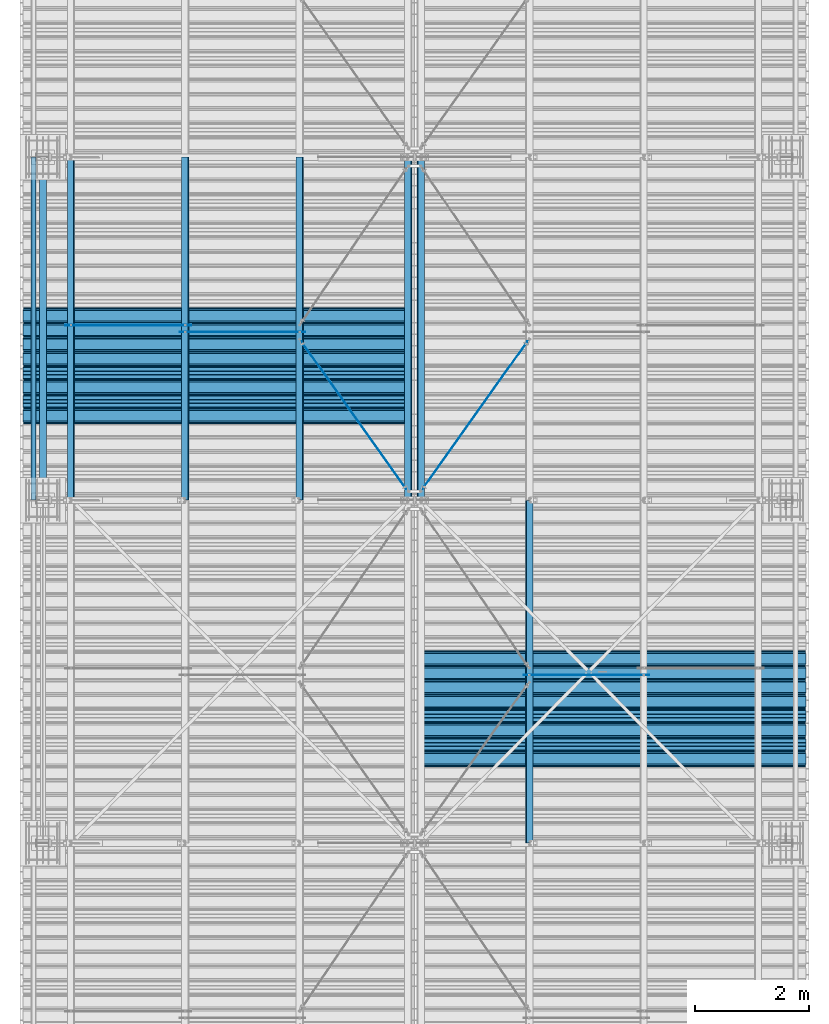
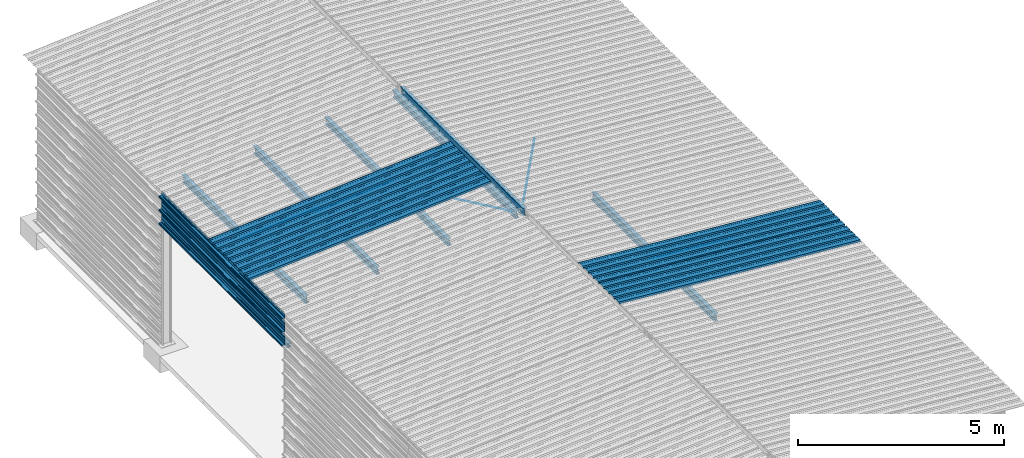
# One storey, part 12 of 70: 19 beams, 19 elements without a shape of their own.
"""IFC2X3 building model written with IfcOpenShell, lengths in millimetres."""

from ifc_helpers import new_model, si_unit, frame, origin_with_axes, origin_2d_with_axis, place, context, subcontext, project, spatial, polyline, circle, i_section, outline, extrude, clip, halfspace, material, type_object, element, aggregate, save


model = new_model("IFC2X3")

# Units and contexts
model_context = context("Model", 3, precision=1e-05, world=origin_with_axes())
body_context = subcontext(model_context, "Body", "Model", "MODEL_VIEW")
ifc_project = project(units=[si_unit("LENGTHUNIT", "METRE", prefix="MILLI"), si_unit("AREAUNIT", "SQUARE_METRE"), si_unit("VOLUMEUNIT", "CUBIC_METRE"), si_unit("MASSUNIT", "GRAM", prefix="KILO"), si_unit("TIMEUNIT", "SECOND"), si_unit("PLANEANGLEUNIT", "RADIAN"), si_unit("SOLIDANGLEUNIT", "STERADIAN"), si_unit("THERMODYNAMICTEMPERATUREUNIT", "DEGREE_CELSIUS"), si_unit("LUMINOUSINTENSITYUNIT", "LUMEN")], contexts=[model_context])

# Site, building, storey
site_placement = place(None, origin_with_axes())
site = spatial("IfcSite", under=ifc_project, at=site_placement, CompositionType="ELEMENT")
building_placement = place(site_placement, origin_with_axes())
building = spatial("IfcBuilding", under=site, at=building_placement, Name="Undefined", CompositionType="ELEMENT")
storey_placement = place(building_placement, origin_with_axes())
storey = spatial("IfcBuildingStorey", under=building, at=storey_placement, Name="Undefined", CompositionType="ELEMENT", Elevation=0.0)

# Assembly, beam
assembly_1_placement = place(storey_placement, origin_with_axes())
assembly_1 = element("IfcElementAssembly", 1, at=assembly_1_placement, inside=storey, Name="Steel Assembly", AssemblyPlace="NOTDEFINED", PredefinedType="RIGID_FRAME")
ifc_material = material(Name="STEEL/S235JR")
beam_type_1 = type_object("IfcBeamType", Name="4.40", PredefinedType="NOTDEFINED")
beam_1_placement = place(assembly_1_placement, frame((6563.60751131961, 7850.00000000015, 5336.31760454372), z_axis=(-0.0766964990376782, 0.0, -0.997054485489817), x_axis=(0.997054485489817, 0.0, -0.0766964990376783)))
beam_1 = element("IfcBeam", 2, at=beam_1_placement, type_object=beam_type_1, material=ifc_material, ObjectType="4.40", context=body_context, shape_type="SweptSolid", body=[
    extrude(outline(polyline([(509.415161132813, 19.5000000011705), (490.584838867188, 19.5000000011705), (468.084838867188, -20.4999999988113), (406.585784912109, -20.4999999988113), (404.585784912109, -18.4999999988122), (345.414215087891, -18.4999999988122), (343.414215087891, -20.4999999988113), (281.915161132813, -20.4999999988113), (259.415161132813, 19.5000000011705), (240.584854125977, 19.5000000011705), (218.084854125977, -20.4999999988113), (156.585784912109, -20.4999999988113), (154.585784912109, -18.4999999988122), (95.4142150878906, -18.4999999988122), (93.4142150878906, -20.4999999988113), (31.9151515960693, -20.4999999988113), (9.41515254974365, 19.5000000011705), (-9.41515254974365, 19.5000000011705), (-31.9151515960693, -20.4999999988113), (-93.4142150878906, -20.4999999988113), (-95.4142150878906, -18.4999999988122), (-154.585784912109, -18.4999999988122), (-156.585784912109, -20.4999999988113), (-218.084854125977, -20.4999999988113), (-240.584854125977, 19.5000000011705), (-259.415161132813, 19.5000000011705), (-281.915161132813, -20.4999999988113), (-343.414215087891, -20.4999999988113), (-345.414215087891, -18.4999999988122), (-404.585784912109, -18.4999999988122), (-406.585784912109, -20.4999999988113), (-468.084838867188, -20.4999999988113), (-490.584838867188, 19.5000000011705), (-509.415161132813, 19.5000000011705), (-516.482360839844, 6.9361057293263), (-517.353942871094, 7.42636680720625), (-510.0, 20.5000000011705), (-490.0, 20.5000000011705), (-467.5, -19.4999999988122), (-407.0, -19.4999999988122), (-405.0, -17.4999999988131), (-345.0, -17.4999999988131), (-343.0, -19.4999999988122), (-282.5, -19.4999999988122), (-260.0, 20.5000000011705), (-240.0, 20.5000000011705), (-217.5, -19.4999999988122), (-157.0, -19.4999999988122), (-155.0, -17.4999999988131), (-95.0, -17.4999999988131), (-93.0, -19.4999999988122), (-32.5, -19.4999999988122), (-10.0, 20.5000000011705), (10.0, 20.5000000011705), (32.5, -19.4999999988122), (93.0, -19.4999999988122), (95.0, -17.4999999988131), (155.0, -17.4999999988131), (157.0, -19.4999999988122), (217.5, -19.4999999988122), (240.0, 20.5000000011705), (260.0, 20.5000000011705), (282.5, -19.4999999988122), (343.0, -19.4999999988122), (345.0, -17.4999999988131), (405.0, -17.4999999988131), (407.0, -19.4999999988122), (467.5, -19.4999999988122), (490.0, 20.5000000011705), (510.0, 20.5000000011705), (517.353942871094, 7.42636680720625), (516.482360839844, 6.9361057293263), (509.415161132813, 19.5000000011705)])), frame((6799.99999999733, 2.8421709430404e-14, 0.0), z_axis=(-1.0, 0.0, 0.0), x_axis=(0.0, -1.0, 0.0)), (0.0, 0.0, 1.0), 6800.0),
])
aggregate(assembly_1, [beam_1])

assembly_2_placement = place(storey_placement, origin_with_axes())
assembly_2 = element("IfcElementAssembly", 3, at=assembly_2_placement, inside=storey, Name="Steel Assembly", AssemblyPlace="NOTDEFINED", PredefinedType="RIGID_FRAME")
beam_2_placement = place(assembly_2_placement, frame((6563.60751131961, 8850.00000000015, 5336.31760454375), z_axis=(-0.0766964990376782, 0.0, -0.997054485489817), x_axis=(0.997054485489817, 0.0, -0.0766964990376783)))
beam_2 = element("IfcBeam", 4, at=beam_2_placement, type_object=beam_type_1, material=ifc_material, ObjectType="4.40", context=body_context, shape_type="SweptSolid", body=[
    extrude(outline(polyline([(509.415161132813, 19.5000000011705), (490.584838867188, 19.5000000011705), (468.084838867188, -20.4999999988113), (406.585784912109, -20.4999999988113), (404.585784912109, -18.4999999988122), (345.414215087891, -18.4999999988122), (343.414215087891, -20.4999999988113), (281.915161132813, -20.4999999988113), (259.415161132813, 19.5000000011705), (240.584854125977, 19.5000000011705), (218.084854125977, -20.4999999988113), (156.585784912109, -20.4999999988113), (154.585784912109, -18.4999999988122), (95.4142150878906, -18.4999999988122), (93.4142150878906, -20.4999999988113), (31.9151515960693, -20.4999999988113), (9.41515254974365, 19.5000000011705), (-9.41515254974365, 19.5000000011705), (-31.9151515960693, -20.4999999988113), (-93.4142150878906, -20.4999999988113), (-95.4142150878906, -18.4999999988122), (-154.585784912109, -18.4999999988122), (-156.585784912109, -20.4999999988113), (-218.084854125977, -20.4999999988113), (-240.584854125977, 19.5000000011705), (-259.415161132813, 19.5000000011705), (-281.915161132813, -20.4999999988113), (-343.414215087891, -20.4999999988113), (-345.414215087891, -18.4999999988122), (-404.585784912109, -18.4999999988122), (-406.585784912109, -20.4999999988113), (-468.084838867188, -20.4999999988113), (-490.584838867188, 19.5000000011705), (-509.415161132813, 19.5000000011705), (-516.482360839844, 6.9361057293263), (-517.353942871094, 7.42636680720625), (-510.0, 20.5000000011705), (-490.0, 20.5000000011705), (-467.5, -19.4999999988122), (-407.0, -19.4999999988122), (-405.0, -17.4999999988131), (-345.0, -17.4999999988131), (-343.0, -19.4999999988122), (-282.5, -19.4999999988122), (-260.0, 20.5000000011705), (-240.0, 20.5000000011705), (-217.5, -19.4999999988122), (-157.0, -19.4999999988122), (-155.0, -17.4999999988131), (-95.0, -17.4999999988131), (-93.0, -19.4999999988122), (-32.5, -19.4999999988122), (-10.0, 20.5000000011705), (10.0, 20.5000000011705), (32.5, -19.4999999988122), (93.0, -19.4999999988122), (95.0, -17.4999999988131), (155.0, -17.4999999988131), (157.0, -19.4999999988122), (217.5, -19.4999999988122), (240.0, 20.5000000011705), (260.0, 20.5000000011705), (282.5, -19.4999999988122), (343.0, -19.4999999988122), (345.0, -17.4999999988131), (405.0, -17.4999999988131), (407.0, -19.4999999988122), (467.5, -19.4999999988122), (490.0, 20.5000000011705), (510.0, 20.5000000011705), (517.353942871094, 7.42636680720625), (516.482360839844, 6.9361057293263), (509.415161132813, 19.5000000011705)])), frame((6799.99999999733, 2.8421709430404e-14, 0.0), z_axis=(-1.0, 0.0, 0.0), x_axis=(0.0, -1.0, 0.0)), (0.0, 0.0, 1.0), 6800.0),
])
aggregate(assembly_2, [beam_2])

assembly_3_placement = place(storey_placement, origin_with_axes())
assembly_3 = element("IfcElementAssembly", 5, at=assembly_3_placement, inside=storey, Name="Steel Assembly", AssemblyPlace="NOTDEFINED", PredefinedType="RIGID_FRAME")
beam_3_placement = place(assembly_3_placement, frame((6436.39248868039, 13850.0, 5336.31760454388), z_axis=(0.0766964990376782, 0.0, -0.997054485489817), x_axis=(-0.997054485489818, 0.0, -0.0766964990376602)))
beam_3 = element("IfcBeam", 6, at=beam_3_placement, type_object=beam_type_1, material=ifc_material, ObjectType="4.40", context=body_context, shape_type="SweptSolid", body=[
    extrude(outline(polyline([(509.415161132813, 19.5000000011705), (490.584838867188, 19.5000000011705), (468.084838867188, -20.4999999988113), (406.585784912109, -20.4999999988113), (404.585784912109, -18.4999999988122), (345.414215087891, -18.4999999988122), (343.414215087891, -20.4999999988113), (281.915161132813, -20.4999999988113), (259.415161132813, 19.5000000011705), (240.584854125977, 19.5000000011705), (218.084854125977, -20.4999999988113), (156.585784912109, -20.4999999988113), (154.585784912109, -18.4999999988122), (95.4142150878906, -18.4999999988122), (93.4142150878906, -20.4999999988113), (31.9151515960693, -20.4999999988113), (9.41515254974365, 19.5000000011705), (-9.41515254974365, 19.5000000011705), (-31.9151515960693, -20.4999999988113), (-93.4142150878906, -20.4999999988113), (-95.4142150878906, -18.4999999988122), (-154.585784912109, -18.4999999988122), (-156.585784912109, -20.4999999988113), (-218.084854125977, -20.4999999988113), (-240.584854125977, 19.5000000011705), (-259.415161132813, 19.5000000011705), (-281.915161132813, -20.4999999988113), (-343.414215087891, -20.4999999988113), (-345.414215087891, -18.4999999988122), (-404.585784912109, -18.4999999988122), (-406.585784912109, -20.4999999988113), (-468.084838867188, -20.4999999988113), (-490.584838867188, 19.5000000011705), (-509.415161132813, 19.5000000011705), (-516.482360839844, 6.9361057293263), (-517.353942871094, 7.42636680720625), (-510.0, 20.5000000011705), (-490.0, 20.5000000011705), (-467.5, -19.4999999988122), (-407.0, -19.4999999988122), (-405.0, -17.4999999988131), (-345.0, -17.4999999988131), (-343.0, -19.4999999988122), (-282.5, -19.4999999988122), (-260.0, 20.5000000011705), (-240.0, 20.5000000011705), (-217.5, -19.4999999988122), (-157.0, -19.4999999988122), (-155.0, -17.4999999988131), (-95.0, -17.4999999988131), (-93.0, -19.4999999988122), (-32.5, -19.4999999988122), (-10.0, 20.5000000011705), (10.0, 20.5000000011705), (32.5, -19.4999999988122), (93.0, -19.4999999988122), (95.0, -17.4999999988131), (155.0, -17.4999999988131), (157.0, -19.4999999988122), (217.5, -19.4999999988122), (240.0, 20.5000000011705), (260.0, 20.5000000011705), (282.5, -19.4999999988122), (343.0, -19.4999999988122), (345.0, -17.4999999988131), (405.0, -17.4999999988131), (407.0, -19.4999999988122), (467.5, -19.4999999988122), (490.0, 20.5000000011705), (510.0, 20.5000000011705), (517.353942871094, 7.42636680720625), (516.482360839844, 6.9361057293263), (509.415161132813, 19.5000000011705)])), frame((6799.99999999733, 2.8421709430404e-14, 0.0), z_axis=(-1.0, 0.0, 0.0), x_axis=(0.0, -1.0, 0.0)), (0.0, 0.0, 1.0), 6800.0),
])
aggregate(assembly_3, [beam_3])

assembly_4_placement = place(storey_placement, origin_with_axes())
assembly_4 = element("IfcElementAssembly", 7, at=assembly_4_placement, inside=storey, Name="Steel Assembly", AssemblyPlace="NOTDEFINED", PredefinedType="RIGID_FRAME")
beam_4_placement = place(assembly_4_placement, frame((6436.39248868039, 14850.0, 5336.31760454388), z_axis=(0.0766964990376782, 0.0, -0.997054485489817), x_axis=(-0.997054485489818, 0.0, -0.0766964990376602)))
beam_4 = element("IfcBeam", 8, at=beam_4_placement, type_object=beam_type_1, material=ifc_material, ObjectType="4.40", context=body_context, shape_type="SweptSolid", body=[
    extrude(outline(polyline([(509.415161132813, 19.5000000011705), (490.584838867188, 19.5000000011705), (468.084838867188, -20.4999999988113), (406.585784912109, -20.4999999988113), (404.585784912109, -18.4999999988122), (345.414215087891, -18.4999999988122), (343.414215087891, -20.4999999988113), (281.915161132813, -20.4999999988113), (259.415161132813, 19.5000000011705), (240.584854125977, 19.5000000011705), (218.084854125977, -20.4999999988113), (156.585784912109, -20.4999999988113), (154.585784912109, -18.4999999988122), (95.4142150878906, -18.4999999988122), (93.4142150878906, -20.4999999988113), (31.9151515960693, -20.4999999988113), (9.41515254974365, 19.5000000011705), (-9.41515254974365, 19.5000000011705), (-31.9151515960693, -20.4999999988113), (-93.4142150878906, -20.4999999988113), (-95.4142150878906, -18.4999999988122), (-154.585784912109, -18.4999999988122), (-156.585784912109, -20.4999999988113), (-218.084854125977, -20.4999999988113), (-240.584854125977, 19.5000000011705), (-259.415161132813, 19.5000000011705), (-281.915161132813, -20.4999999988113), (-343.414215087891, -20.4999999988113), (-345.414215087891, -18.4999999988122), (-404.585784912109, -18.4999999988122), (-406.585784912109, -20.4999999988113), (-468.084838867188, -20.4999999988113), (-490.584838867188, 19.5000000011705), (-509.415161132813, 19.5000000011705), (-516.482360839844, 6.9361057293263), (-517.353942871094, 7.42636680720625), (-510.0, 20.5000000011705), (-490.0, 20.5000000011705), (-467.5, -19.4999999988122), (-407.0, -19.4999999988122), (-405.0, -17.4999999988131), (-345.0, -17.4999999988131), (-343.0, -19.4999999988122), (-282.5, -19.4999999988122), (-260.0, 20.5000000011705), (-240.0, 20.5000000011705), (-217.5, -19.4999999988122), (-157.0, -19.4999999988122), (-155.0, -17.4999999988131), (-95.0, -17.4999999988131), (-93.0, -19.4999999988122), (-32.5, -19.4999999988122), (-10.0, 20.5000000011705), (10.0, 20.5000000011705), (32.5, -19.4999999988122), (93.0, -19.4999999988122), (95.0, -17.4999999988131), (155.0, -17.4999999988131), (157.0, -19.4999999988122), (217.5, -19.4999999988122), (240.0, 20.5000000011705), (260.0, 20.5000000011705), (282.5, -19.4999999988122), (343.0, -19.4999999988122), (345.0, -17.4999999988131), (405.0, -17.4999999988131), (407.0, -19.4999999988122), (467.5, -19.4999999988122), (490.0, 20.5000000011705), (510.0, 20.5000000011705), (517.353942871094, 7.42636680720625), (516.482360839844, 6.9361057293263), (509.415161132813, 19.5000000011705)])), frame((6799.99999999733, 2.8421709430404e-14, 0.0), z_axis=(-1.0, 0.0, 0.0), x_axis=(0.0, -1.0, 0.0)), (0.0, 0.0, 1.0), 6800.0),
])
aggregate(assembly_4, [beam_4])

assembly_5_placement = place(storey_placement, origin_with_axes())
assembly_5 = element("IfcElementAssembly", 9, at=assembly_5_placement, inside=storey, Name="Steel Assembly", AssemblyPlace="NOTDEFINED", PredefinedType="RIGID_FRAME")
beam_type_2 = type_object("IfcBeamType", Name="400", PredefinedType="NOTDEFINED")
beam_5_placement = place(assembly_5_placement, frame((-165.499999998334, 12000.0, 4618.17396601053), z_axis=(-1.0, 0.0, 0.0), x_axis=(0.0, 1.0, 0.0)))
beam_5 = element("IfcBeam", 10, at=beam_5_placement, type_object=beam_type_2, material=ifc_material, ObjectType="400", context=body_context, shape_type="Clipping", body=[
    clip(extrude(outline(polyline([(218.25, -24.994083404541), (214.25, -31.8999996185303), (214.25, -45.5), (199.75, -45.5), (194.25, -42.5), (188.75, -45.5), (124.25, -45.5), (114.25, -41.5), (104.25, -45.5), (24.25, -45.5), (14.25, -41.5), (4.25, -45.5), (-75.75, -45.5), (-85.75, -41.5), (-95.75, -45.5), (-160.25, -45.5), (-165.75, -42.5), (-171.25, -45.5), (-185.75, -45.5), (-185.75, -30.711540222168), (-181.75, -23.8111782073975), (-181.75, 23.311637878418), (-185.75, 30.2119998931885), (-185.75, 44.5), (-217.25, 44.5), (-217.25, 34.7999992370605), (-218.25, 34.7999992370605), (-218.25, 45.5), (-184.75, 45.5), (-184.75, 30.480884552002), (-180.75, 23.5805225372314), (-180.75, -24.0800628662109), (-184.75, -30.9804248809814), (-184.75, -44.5), (-171.504989624023, -44.5), (-165.75, -41.360912322998), (-159.995010375977, -44.5), (-95.9425811767578, -44.5), (-85.75, -40.422966003418), (-75.5574188232422, -44.5), (4.05741739273071, -44.5), (14.25, -40.422966003418), (24.4425830841064, -44.5), (104.057418823242, -44.5), (114.25, -40.422966003418), (124.442581176758, -44.5), (188.495010375977, -44.5), (194.25, -41.360912322998), (200.004989624023, -44.5), (213.25, -44.5), (213.25, -31.6313018798828), (217.25, -24.7253856658936), (217.25, 21.7253856658936), (213.25, 28.6313018798828), (213.25, 42.0), (187.25, 42.0), (187.25, 32.5499992370605), (186.25, 32.5499992370605), (186.25, 43.0), (214.25, 43.0), (214.25, 28.8999996185303), (218.25, 21.994083404541), (218.25, -24.994083404541)])), frame((6000.0, 0.0, 0.0), z_axis=(-1.0, 0.0, 0.0), x_axis=(0.0, -1.0, 0.0)), (0.0, 0.0, 1.0), 6000.0), halfspace(frame((5.6843418860808e-14, 36.6804312648874, -45.0000000000003), z_axis=(0.0, -1.0, 0.0), x_axis=(0.0, 0.0, 1.0)), False)),
])
aggregate(assembly_5, [beam_5])

assembly_6_placement = place(storey_placement, origin_with_axes())
assembly_6 = element("IfcElementAssembly", 11, at=assembly_6_placement, inside=storey, Name="Steel Assembly", AssemblyPlace="NOTDEFINED", PredefinedType="RIGID_FRAME")
beam_6_placement = place(assembly_6_placement, frame((-165.499999998485, 12000.0, 4218.17396601053), z_axis=(-1.0, 0.0, 0.0), x_axis=(0.0, 1.0, 0.0)))
beam_6 = element("IfcBeam", 12, at=beam_6_placement, type_object=beam_type_2, material=ifc_material, ObjectType="400", context=body_context, shape_type="SweptSolid", body=[
    extrude(outline(polyline([(218.25, -24.994083404541), (214.25, -31.8999996185303), (214.25, -45.5), (199.75, -45.5), (194.25, -42.5), (188.75, -45.5), (124.25, -45.5), (114.25, -41.5), (104.25, -45.5), (24.25, -45.5), (14.25, -41.5), (4.25, -45.5), (-75.75, -45.5), (-85.75, -41.5), (-95.75, -45.5), (-160.25, -45.5), (-165.75, -42.5), (-171.25, -45.5), (-185.75, -45.5), (-185.75, -30.711540222168), (-181.75, -23.8111782073975), (-181.75, 23.311637878418), (-185.75, 30.2119998931885), (-185.75, 44.5), (-217.25, 44.5), (-217.25, 34.7999992370605), (-218.25, 34.7999992370605), (-218.25, 45.5), (-184.75, 45.5), (-184.75, 30.480884552002), (-180.75, 23.5805225372314), (-180.75, -24.0800628662109), (-184.75, -30.9804248809814), (-184.75, -44.5), (-171.504989624023, -44.5), (-165.75, -41.360912322998), (-159.995010375977, -44.5), (-95.9425811767578, -44.5), (-85.75, -40.422966003418), (-75.5574188232422, -44.5), (4.05741739273071, -44.5), (14.25, -40.422966003418), (24.4425830841064, -44.5), (104.057418823242, -44.5), (114.25, -40.422966003418), (124.442581176758, -44.5), (188.495010375977, -44.5), (194.25, -41.360912322998), (200.004989624023, -44.5), (213.25, -44.5), (213.25, -31.6313018798828), (217.25, -24.7253856658936), (217.25, 21.7253856658936), (213.25, 28.6313018798828), (213.25, 42.0), (187.25, 42.0), (187.25, 32.5499992370605), (186.25, 32.5499992370605), (186.25, 43.0), (214.25, 43.0), (214.25, 28.8999996185303), (218.25, 21.994083404541), (218.25, -24.994083404541)])), frame((6000.0, 0.0, 0.0), z_axis=(-1.0, 0.0, 0.0), x_axis=(0.0, -1.0, 0.0)), (0.0, 0.0, 1.0), 6000.0),
])
aggregate(assembly_6, [beam_6])

assembly_7_placement = place(storey_placement, origin_with_axes())
assembly_7 = element("IfcElementAssembly", 13, at=assembly_7_placement, inside=storey, Name="Steel Assembly", AssemblyPlace="NOTDEFINED", PredefinedType="RIGID_FRAME")
beam_7_placement = place(assembly_7_placement, frame((-165.499999998638, 12000.0, 3818.17396601053), z_axis=(-1.0, 0.0, 0.0), x_axis=(0.0, 1.0, 0.0)))
beam_7 = element("IfcBeam", 14, at=beam_7_placement, type_object=beam_type_2, material=ifc_material, ObjectType="400", context=body_context, shape_type="SweptSolid", body=[
    extrude(outline(polyline([(218.25, -24.994083404541), (214.25, -31.8999996185303), (214.25, -45.5), (199.75, -45.5), (194.25, -42.5), (188.75, -45.5), (124.25, -45.5), (114.25, -41.5), (104.25, -45.5), (24.25, -45.5), (14.25, -41.5), (4.25, -45.5), (-75.75, -45.5), (-85.75, -41.5), (-95.75, -45.5), (-160.25, -45.5), (-165.75, -42.5), (-171.25, -45.5), (-185.75, -45.5), (-185.75, -30.711540222168), (-181.75, -23.8111782073975), (-181.75, 23.311637878418), (-185.75, 30.2119998931885), (-185.75, 44.5), (-217.25, 44.5), (-217.25, 34.7999992370605), (-218.25, 34.7999992370605), (-218.25, 45.5), (-184.75, 45.5), (-184.75, 30.480884552002), (-180.75, 23.5805225372314), (-180.75, -24.0800628662109), (-184.75, -30.9804248809814), (-184.75, -44.5), (-171.504989624023, -44.5), (-165.75, -41.360912322998), (-159.995010375977, -44.5), (-95.9425811767578, -44.5), (-85.75, -40.422966003418), (-75.5574188232422, -44.5), (4.05741739273071, -44.5), (14.25, -40.422966003418), (24.4425830841064, -44.5), (104.057418823242, -44.5), (114.25, -40.422966003418), (124.442581176758, -44.5), (188.495010375977, -44.5), (194.25, -41.360912322998), (200.004989624023, -44.5), (213.25, -44.5), (213.25, -31.6313018798828), (217.25, -24.7253856658936), (217.25, 21.7253856658936), (213.25, 28.6313018798828), (213.25, 42.0), (187.25, 42.0), (187.25, 32.5499992370605), (186.25, 32.5499992370605), (186.25, 43.0), (214.25, 43.0), (214.25, 28.8999996185303), (218.25, 21.994083404541), (218.25, -24.994083404541)])), frame((6000.0, 0.0, 0.0), z_axis=(-1.0, 0.0, 0.0), x_axis=(0.0, -1.0, 0.0)), (0.0, 0.0, 1.0), 6000.0),
])
aggregate(assembly_7, [beam_7])

assembly_8_placement = place(storey_placement, origin_with_axes())
assembly_8 = element("IfcElementAssembly", 15, at=assembly_8_placement, inside=storey, Name="Steel Assembly", AssemblyPlace="NOTDEFINED", PredefinedType="RIGID_FRAME")
beam_type_3 = type_object("IfcBeamType", Name="HEA120", PredefinedType="NOTDEFINED")
beam_8_placement = place(assembly_8_placement, frame((-3.33582761413709e-09, 18000.0, 3561.43389561758), z_axis=(0.0, 0.0, 1.0), x_axis=(0.0, -1.0, 0.0)))
beam_8 = element("IfcBeam", 16, at=beam_8_placement, type_object=beam_type_3, material=ifc_material, Name="POUTRE", ObjectType="HEA120", context=body_context, shape_type="Clipping", body=[
    clip(clip(extrude(i_section(OverallWidth=120.0, OverallDepth=114.0, WebThickness=5.0, FlangeThickness=8.0, FilletRadius=12.0, at=origin_2d_with_axis()), frame((5986.9000000955, 0.0, 0.0), z_axis=(-1.0, 0.0, 0.0), x_axis=(0.0, -1.0, 0.0)), (0.0, 0.0, 1.0), 5973.8), halfspace(frame((5986.9000000955, 0.0, -57.0), z_axis=(-1.0, 0.0, 0.0), x_axis=(0.0, 1.0, 0.0)), True)), halfspace(frame((13.0999999045016, 0.0, -57.0), z_axis=(1.0, 0.0, 0.0), x_axis=(0.0, -1.0, 0.0)), True)),
])
aggregate(assembly_8, [beam_8])

assembly_9_placement = place(storey_placement, origin_with_axes())
assembly_9 = element("IfcElementAssembly", 17, at=assembly_9_placement, inside=storey, Name="Steel Assembly", AssemblyPlace="NOTDEFINED", PredefinedType="RIGID_FRAME")
beam_type_4 = type_object("IfcBeamType", Name="D14", PredefinedType="NOTDEFINED")
beam_9_placement = place(assembly_9_placement, frame((6356.85674631885, 12198.7719608751, 5199.31394476533), z_axis=(0.0766964990376782, 0.0, -0.997054485489817), x_axis=(-0.57921819911489, 0.813953996161451, -0.0445552460088377)))
beam_9 = element("IfcBeam", 18, at=beam_9_placement, type_object=beam_type_4, material=ifc_material, Name="THREAD60MM", ObjectType="D14", context=body_context, shape_type="SweptSolid", body=[
    extrude(circle(Radius=7.0, at=origin_2d_with_axis()), frame((3168.99270027986, -1.70491988837408e-12, 2.19893041294984e-14), z_axis=(-1.0, 0.0, 0.0), x_axis=(0.0, -1.0, 0.0)), (0.0, 0.0, 1.0), 3168.99),
])
aggregate(assembly_9, [beam_9])

assembly_10_placement = place(storey_placement, origin_with_axes())
assembly_10 = element("IfcElementAssembly", 19, at=assembly_10_placement, inside=storey, Name="Steel Assembly", AssemblyPlace="NOTDEFINED", PredefinedType="RIGID_FRAME")
beam_10_placement = place(assembly_10_placement, frame((2591.26883365322, 15060.0000000001, 4909.65333500212), z_axis=(0.0766964990376782, 0.0, -0.997054485489817), x_axis=(-0.997054485489818, 0.0, -0.0766964990376602)))
beam_10 = element("IfcBeam", 20, at=beam_10_placement, type_object=beam_type_4, material=ifc_material, Name="THREAD60MM", ObjectType="D14", context=body_context, shape_type="SweptSolid", body=[
    extrude(circle(Radius=7.0, at=origin_2d_with_axis()), frame((2205.90843239298, 9.09494701772928e-13, -9.40107830921147e-13), z_axis=(-1.0, 0.0, 0.0), x_axis=(0.0, -1.0, 0.0)), (0.0, 0.0, 1.0), 2205.91),
])
aggregate(assembly_10, [beam_10])

assembly_11_placement = place(storey_placement, origin_with_axes())
assembly_11 = element("IfcElementAssembly", 21, at=assembly_11_placement, inside=storey, Name="Steel Assembly", AssemblyPlace="NOTDEFINED", PredefinedType="RIGID_FRAME")
beam_11_placement = place(assembly_11_placement, frame((4591.26883365324, 14940.0000000001, 5063.49948915789), z_axis=(0.0766964990376782, 0.0, -0.997054485489817), x_axis=(-0.997054485489818, 0.0, -0.0766964990376602)))
beam_11 = element("IfcBeam", 22, at=beam_11_placement, type_object=beam_type_4, material=ifc_material, Name="THREAD60MM", ObjectType="D14", context=body_context, shape_type="SweptSolid", body=[
    extrude(circle(Radius=7.0, at=origin_2d_with_axis()), frame((2205.90843239298, 9.09494701772928e-13, -9.40107830921147e-13), z_axis=(-1.0, 0.0, 0.0), x_axis=(0.0, -1.0, 0.0)), (0.0, 0.0, 1.0), 2205.91),
])
aggregate(assembly_11, [beam_11])

assembly_12_placement = place(storey_placement, origin_with_axes())
assembly_12 = element("IfcElementAssembly", 23, at=assembly_12_placement, inside=storey, Name="Steel Assembly", AssemblyPlace="NOTDEFINED", PredefinedType="RIGID_FRAME")
beam_12_placement = place(assembly_12_placement, frame((8408.73116634676, 8940.00000000009, 5063.49948915789), z_axis=(-0.0766964990376782, 0.0, -0.997054485489817), x_axis=(0.997054485489817, 0.0, -0.0766964990376783)))
beam_12 = element("IfcBeam", 24, at=beam_12_placement, type_object=beam_type_4, material=ifc_material, Name="THREAD60MM", ObjectType="D14", context=body_context, shape_type="SweptSolid", body=[
    extrude(circle(Radius=7.0, at=origin_2d_with_axis()), frame((2205.90843239298, 9.09494701772928e-13, -9.40107830921147e-13), z_axis=(-1.0, 0.0, 0.0), x_axis=(0.0, -1.0, 0.0)), (0.0, 0.0, 1.0), 2205.91),
])
aggregate(assembly_12, [beam_12])

assembly_13_placement = place(storey_placement, origin_with_axes())
assembly_13 = element("IfcElementAssembly", 25, at=assembly_13_placement, inside=storey, Name="Steel Assembly", AssemblyPlace="NOTDEFINED", PredefinedType="RIGID_FRAME")
beam_13_placement = place(assembly_13_placement, frame((6608.43661486537, 12150.0000000142, 5201.98368622754), z_axis=(-0.0766964990376782, 0.0, -0.997054485489817), x_axis=(0.57921819911489, 0.813953996161451, -0.0445552460088378)))
beam_13 = element("IfcBeam", 26, at=beam_13_placement, type_object=beam_type_4, material=ifc_material, Name="THREAD60MM", ObjectType="D14", context=body_context, shape_type="Clipping", body=[
    clip(extrude(circle(Radius=7.0, at=origin_2d_with_axis()), frame((3228.91250054543, 7.28165141154247e-14, -8.87089620506644e-13), z_axis=(-1.0, 0.0, 0.0), x_axis=(0.0, -1.0, 0.0)), (0.0, 0.0, 1.0), 3192.8), halfspace(frame((50.078070326661, 50.0000000243217, -1.19907781481743e-08), z_axis=(1.0, 0.0, 0.0), x_axis=(0.0, 0.0, -1.0)), True)),
])
aggregate(assembly_13, [beam_13])

assembly_14_placement = place(storey_placement, origin_with_axes())
assembly_14 = element("IfcElementAssembly", 27, at=assembly_14_placement, inside=storey, Name="Steel Assembly", AssemblyPlace="NOTDEFINED", PredefinedType="RIGID_FRAME")
beam_type_5 = type_object("IfcBeamType", Name="IPE220", PredefinedType="NOTDEFINED")
beam_14_placement = place(assembly_14_placement, frame((8508.43661489494, 6000.0, 5055.82983925965), z_axis=(0.0766964990376782, 0.0, 0.997054485489817), x_axis=(0.0, 1.0, 0.0)))
beam_14 = element("IfcBeam", 28, at=beam_14_placement, type_object=beam_type_5, material=ifc_material, ObjectType="IPE220", context=body_context, shape_type="Clipping", body=[
    clip(clip(extrude(i_section(OverallWidth=110.0, OverallDepth=220.0, WebThickness=5.900000095, FlangeThickness=9.199999809, FilletRadius=12.0, at=origin_2d_with_axis()), frame((5995.0, 1.81898940354586e-12, 0.0), z_axis=(-1.0, 0.0, 0.0), x_axis=(0.0, -1.0, 0.0)), (0.0, 0.0, 1.0), 5990.0), halfspace(frame((5995.0, 1.81898940354586e-12, 0.0), z_axis=(1.0, 0.0, 0.0), x_axis=(0.0, -1.0, 0.0)), False)), halfspace(frame((4.99999999999636, 7.09405867382884e-11, -1.79170456249267e-10), z_axis=(1.0, 0.0, 0.0), x_axis=(0.0, -1.0, 0.0)), True)),
])
aggregate(assembly_14, [beam_14])

assembly_15_placement = place(storey_placement, origin_with_axes())
assembly_15 = element("IfcElementAssembly", 29, at=assembly_15_placement, inside=storey, Name="Steel Assembly", AssemblyPlace="NOTDEFINED", PredefinedType="RIGID_FRAME")
beam_15_placement = place(assembly_15_placement, frame((6608.4366148551, 12000.0, 5201.98368622854), z_axis=(0.0766964990376782, 0.0, 0.997054485489817), x_axis=(0.0, 1.0, 0.0)))
beam_15 = element("IfcBeam", 30, at=beam_15_placement, type_object=beam_type_5, material=ifc_material, ObjectType="IPE220", context=body_context, shape_type="Clipping", body=[
    clip(clip(extrude(i_section(OverallWidth=110.0, OverallDepth=220.0, WebThickness=5.900000095, FlangeThickness=9.199999809, FilletRadius=12.0, at=origin_2d_with_axis()), frame((5995.0, 1.81898940354586e-12, 0.0), z_axis=(-1.0, 0.0, 0.0), x_axis=(0.0, -1.0, 0.0)), (0.0, 0.0, 1.0), 5990.0), halfspace(frame((5995.0, 1.81898940354586e-12, 0.0), z_axis=(1.0, 0.0, 0.0), x_axis=(0.0, -1.0, 0.0)), False)), halfspace(frame((4.99999999999636, 7.09405867382884e-11, -1.79170456249267e-10), z_axis=(1.0, 0.0, 0.0), x_axis=(0.0, -1.0, 0.0)), True)),
])
aggregate(assembly_15, [beam_15])

assembly_16_placement = place(storey_placement, origin_with_axes())
assembly_16 = element("IfcElementAssembly", 31, at=assembly_16_placement, inside=storey, Name="Steel Assembly", AssemblyPlace="NOTDEFINED", PredefinedType="RIGID_FRAME")
beam_16_placement = place(assembly_16_placement, frame((6391.56338514162, 18000.0, 5201.98368623408), z_axis=(-0.0766964990376602, 0.0, 0.997054485489818), x_axis=(0.0, -1.0, 0.0)))
beam_16 = element("IfcBeam", 32, at=beam_16_placement, type_object=beam_type_5, material=ifc_material, ObjectType="IPE220", context=body_context, shape_type="Clipping", body=[
    clip(clip(extrude(i_section(OverallWidth=110.0, OverallDepth=220.0, WebThickness=5.900000095, FlangeThickness=9.199999809, FilletRadius=12.0, at=origin_2d_with_axis()), frame((5995.0, 1.81898940354586e-12, 0.0), z_axis=(-1.0, 0.0, 0.0), x_axis=(0.0, -1.0, 0.0)), (0.0, 0.0, 1.0), 5990.0), halfspace(frame((5995.0, 1.81898940354586e-12, 0.0), z_axis=(1.0, 0.0, 0.0), x_axis=(0.0, -1.0, 0.0)), False)), halfspace(frame((4.99999999999636, 7.09405867382884e-11, -1.79170456249267e-10), z_axis=(1.0, 0.0, 0.0), x_axis=(0.0, -1.0, 0.0)), True)),
])
aggregate(assembly_16, [beam_16])

assembly_17_placement = place(storey_placement, origin_with_axes())
assembly_17 = element("IfcElementAssembly", 33, at=assembly_17_placement, inside=storey, Name="Steel Assembly", AssemblyPlace="NOTDEFINED", PredefinedType="RIGID_FRAME")
beam_17_placement = place(assembly_17_placement, frame((4491.56338513014, 18000.0, 5055.82983993042), z_axis=(-0.0766964990376602, 0.0, 0.997054485489818), x_axis=(0.0, -1.0, 0.0)))
beam_17 = element("IfcBeam", 34, at=beam_17_placement, type_object=beam_type_5, material=ifc_material, ObjectType="IPE220", context=body_context, shape_type="Clipping", body=[
    clip(extrude(i_section(OverallWidth=110.0, OverallDepth=220.0, WebThickness=5.900000095, FlangeThickness=9.199999809, FilletRadius=12.0, at=origin_2d_with_axis()), frame((5995.0, 1.81898940354586e-12, 0.0), z_axis=(-1.0, 0.0, 0.0), x_axis=(0.0, -1.0, 0.0)), (0.0, 0.0, 1.0), 5995.0), halfspace(frame((5995.0, 1.81898940354586e-12, 0.0), z_axis=(1.0, 0.0, 0.0), x_axis=(0.0, -1.0, 0.0)), False)),
])
aggregate(assembly_17, [beam_17])

assembly_18_placement = place(storey_placement, origin_with_axes())
assembly_18 = element("IfcElementAssembly", 35, at=assembly_18_placement, inside=storey, Name="Steel Assembly", AssemblyPlace="NOTDEFINED", PredefinedType="RIGID_FRAME")
beam_18_placement = place(assembly_18_placement, frame((2491.56338511805, 18000.0, 4901.98368592656), z_axis=(-0.0766964990376602, 0.0, 0.997054485489818), x_axis=(0.0, -1.0, 0.0)))
beam_18 = element("IfcBeam", 36, at=beam_18_placement, type_object=beam_type_5, material=ifc_material, ObjectType="IPE220", context=body_context, shape_type="Clipping", body=[
    clip(extrude(i_section(OverallWidth=110.0, OverallDepth=220.0, WebThickness=5.900000095, FlangeThickness=9.199999809, FilletRadius=12.0, at=origin_2d_with_axis()), frame((5995.0, 1.81898940354586e-12, 0.0), z_axis=(-1.0, 0.0, 0.0), x_axis=(0.0, -1.0, 0.0)), (0.0, 0.0, 1.0), 5995.0), halfspace(frame((5995.0, 1.81898940354586e-12, 0.0), z_axis=(1.0, 0.0, 0.0), x_axis=(0.0, -1.0, 0.0)), False)),
])
aggregate(assembly_18, [beam_18])

assembly_19_placement = place(storey_placement, origin_with_axes())
assembly_19 = element("IfcElementAssembly", 37, at=assembly_19_placement, inside=storey, Name="Steel Assembly", AssemblyPlace="NOTDEFINED", PredefinedType="RIGID_FRAME")
beam_19_placement = place(assembly_19_placement, frame((491.563385106131, 18000.0, 4748.13753192221), z_axis=(-0.0766964990376602, 0.0, 0.997054485489818), x_axis=(0.0, -1.0, 0.0)))
beam_19 = element("IfcBeam", 38, at=beam_19_placement, type_object=beam_type_5, material=ifc_material, ObjectType="IPE220", context=body_context, shape_type="Clipping", body=[
    clip(clip(extrude(i_section(OverallWidth=110.0, OverallDepth=220.0, WebThickness=5.900000095, FlangeThickness=9.199999809, FilletRadius=12.0, at=origin_2d_with_axis()), frame((5995.0, 1.81898940354586e-12, 0.0), z_axis=(-1.0, 0.0, 0.0), x_axis=(0.0, -1.0, 0.0)), (0.0, 0.0, 1.0), 5990.0), halfspace(frame((5995.0, 1.81898940354586e-12, 0.0), z_axis=(1.0, 0.0, 0.0), x_axis=(0.0, -1.0, 0.0)), False)), halfspace(frame((4.99999999999636, 7.09405867382884e-11, -1.79170456249267e-10), z_axis=(1.0, 0.0, 0.0), x_axis=(0.0, -1.0, 0.0)), True)),
])
aggregate(assembly_19, [beam_19])

save(model, "model.ifc")
